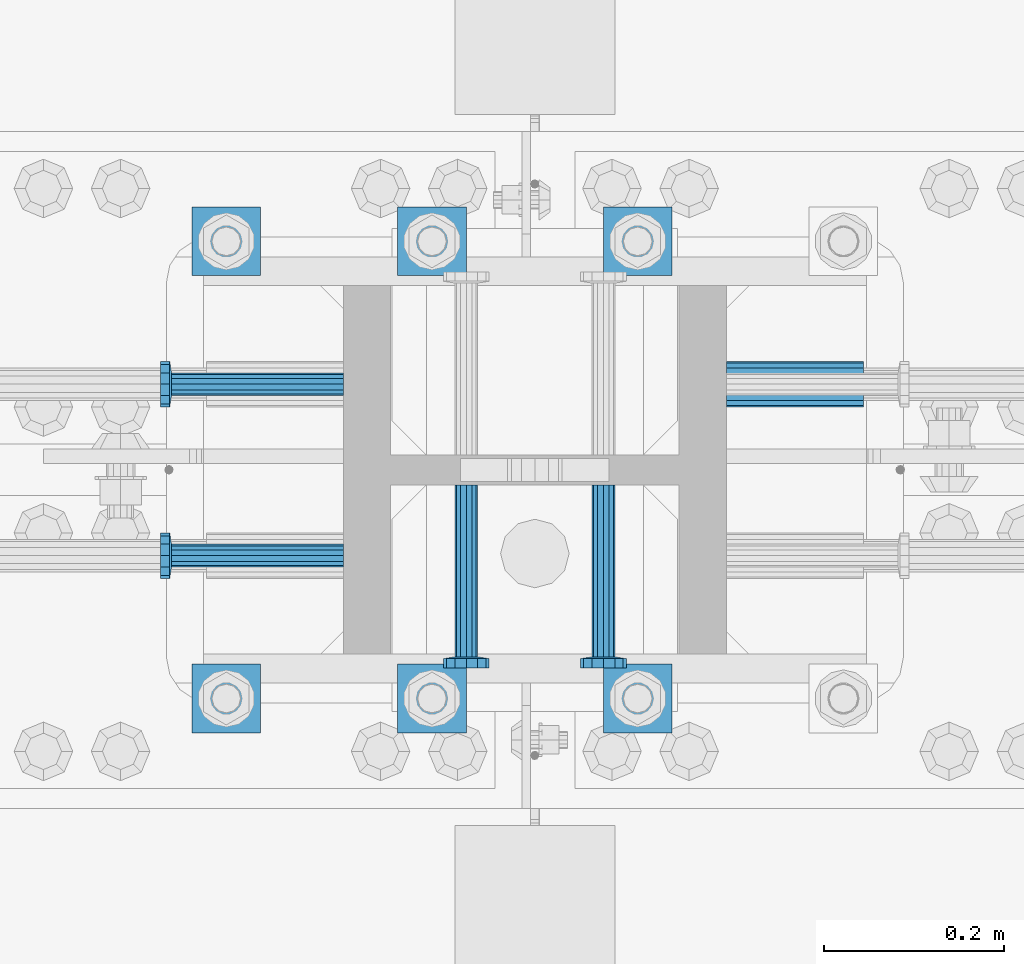
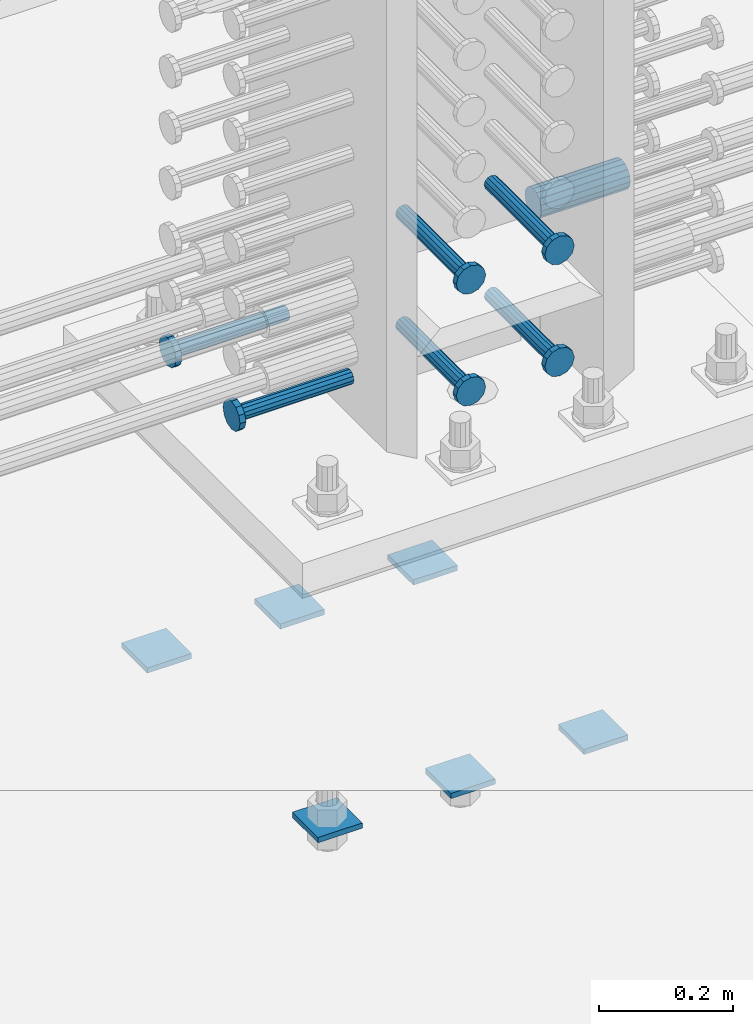
# One storey, part 1231 of 1763: 13 beams, 2 elements without a shape of their own.
"""IFC2X3 building model written with IfcOpenShell, lengths in millimetres."""

from ifc_helpers import new_model, si_unit, frame, origin_with_axes, place, context, subcontext, project, spatial, faceted_brep, material, type_object, element, aggregate, save


model = new_model("IFC2X3")

# Units and contexts
model_context = context("Model", 3, precision=1e-05, world=origin_with_axes())
body_context = subcontext(model_context, "Body", "Model", "MODEL_VIEW")
ifc_project = project(units=[si_unit("LENGTHUNIT", "METRE", prefix="MILLI"), si_unit("AREAUNIT", "SQUARE_METRE"), si_unit("VOLUMEUNIT", "CUBIC_METRE"), si_unit("MASSUNIT", "GRAM", prefix="KILO"), si_unit("TIMEUNIT", "SECOND"), si_unit("PLANEANGLEUNIT", "RADIAN"), si_unit("SOLIDANGLEUNIT", "STERADIAN"), si_unit("THERMODYNAMICTEMPERATUREUNIT", "DEGREE_CELSIUS"), si_unit("LUMINOUSINTENSITYUNIT", "LUMEN")], contexts=[model_context])

# Site, building, storey
site_placement = place(None, origin_with_axes())
site = spatial("IfcSite", under=ifc_project, at=site_placement, CompositionType="ELEMENT")
building_placement = place(site_placement, origin_with_axes())
building = spatial("IfcBuilding", under=site, at=building_placement, Name="Undefined", CompositionType="ELEMENT")
storey_placement = place(building_placement, origin_with_axes())
storey = spatial("IfcBuildingStorey", under=building, at=storey_placement, Name="Undefined", CompositionType="ELEMENT", Elevation=0.0)

# Assembly, beams
assembly_1_placement = place(storey_placement, origin_with_axes())
assembly_1 = element("IfcElementAssembly", 1, at=assembly_1_placement, inside=storey, Name="TEMPLATE", AssemblyPlace="NOTDEFINED", PredefinedType="RIGID_FRAME")
ifc_material_1 = material(Name="STEEL/A36")
beam_type_1 = type_object("IfcBeamType", PredefinedType="NOTDEFINED")
beam_1_placement = place(assembly_1_placement, frame((-49250.0372736986, 203.200000000003, 3348.0375), z_axis=(0.0, 1.0, 0.0), x_axis=(-1.0, 0.0, 0.0)))
beam_1 = element("IfcBeam", 2, at=beam_1_placement, type_object=beam_type_1, material=ifc_material_1, Name="WASHER PLATE", context=body_context, shape_type="Brep", body=[
    faceted_brep([(0.0, 4.76249999999709, -38.1000000000004), (0.0, 4.76249999999709, 38.1000000000004), (76.2000000000007, 4.76249999999982, 38.0999999999985), (76.2000000000007, 4.76249999999982, -38.0999999999985), (0.0, -4.76249999999709, 38.1000000000004), (76.2000000000007, -4.76249999999982, 38.0999999999985), (0.0, -4.76249999999709, -38.1000000000004), (76.2000000000007, -4.76249999999982, -38.0999999999985)], [[[0, 1, 2, 3]], [[1, 4, 5, 2]], [[4, 6, 7, 5]], [[6, 0, 3, 7]], [[5, 7, 3, 2]], [[6, 4, 1, 0]]]),
])
beam_2_placement = place(assembly_1_placement, frame((-49250.0372736986, 711.200000000003, 3348.0375), z_axis=(0.0, 1.0, 0.0), x_axis=(-1.0, 0.0, 0.0)))
beam_2 = element("IfcBeam", 3, at=beam_2_placement, type_object=beam_type_1, material=ifc_material_1, Name="WASHER PLATE", context=body_context, shape_type="Brep", body=[
    faceted_brep([(0.0, 4.76249999999709, -38.1000000000004), (0.0, 4.76249999999709, 38.1000000000004), (76.2000000000007, 4.76249999999982, 38.0999999999985), (76.2000000000007, 4.76249999999982, -38.0999999999985), (0.0, -4.76249999999709, 38.1000000000004), (76.2000000000007, -4.76249999999982, 38.0999999999985), (0.0, -4.76249999999709, -38.1000000000004), (76.2000000000007, -4.76249999999982, -38.0999999999985)], [[[0, 1, 2, 3]], [[1, 4, 5, 2]], [[4, 6, 7, 5]], [[6, 0, 3, 7]], [[5, 7, 3, 2]], [[6, 4, 1, 0]]]),
])
beam_3_placement = place(assembly_1_placement, frame((-49478.6372736986, 203.200000000003, 3348.0375), z_axis=(0.0, 1.0, 0.0), x_axis=(-1.0, 0.0, 0.0)))
beam_3 = element("IfcBeam", 4, at=beam_3_placement, type_object=beam_type_1, material=ifc_material_1, Name="WASHER PLATE", context=body_context, shape_type="Brep", body=[
    faceted_brep([(0.0, 4.76249999999709, -38.1000000000004), (0.0, 4.76249999999709, 38.1000000000004), (76.2000000000007, 4.76249999999982, 38.0999999999985), (76.2000000000007, 4.76249999999982, -38.0999999999985), (0.0, -4.76249999999709, 38.1000000000004), (76.2000000000007, -4.76249999999982, 38.0999999999985), (0.0, -4.76249999999709, -38.1000000000004), (76.2000000000007, -4.76249999999982, -38.0999999999985)], [[[0, 1, 2, 3]], [[1, 4, 5, 2]], [[4, 6, 7, 5]], [[6, 0, 3, 7]], [[5, 7, 3, 2]], [[6, 4, 1, 0]]]),
])
beam_4_placement = place(assembly_1_placement, frame((-49478.6372736986, 711.200000000003, 3348.0375), z_axis=(0.0, 1.0, 0.0), x_axis=(-1.0, 0.0, 0.0)))
beam_4 = element("IfcBeam", 5, at=beam_4_placement, type_object=beam_type_1, material=ifc_material_1, Name="WASHER PLATE", context=body_context, shape_type="Brep", body=[
    faceted_brep([(0.0, 4.76249999999709, -38.1000000000004), (0.0, 4.76249999999709, 38.1000000000004), (76.2000000000007, 4.76249999999982, 38.0999999999985), (76.2000000000007, 4.76249999999982, -38.0999999999985), (0.0, -4.76249999999709, 38.1000000000004), (76.2000000000007, -4.76249999999982, 38.0999999999985), (0.0, -4.76249999999709, -38.1000000000004), (76.2000000000007, -4.76249999999982, -38.0999999999985)], [[[0, 1, 2, 3]], [[1, 4, 5, 2]], [[4, 6, 7, 5]], [[6, 0, 3, 7]], [[5, 7, 3, 2]], [[6, 4, 1, 0]]]),
])
beam_5_placement = place(assembly_1_placement, frame((-49707.2372736986, 203.200000000003, 3348.0375), z_axis=(0.0, 1.0, 0.0), x_axis=(-1.0, 0.0, 0.0)))
beam_5 = element("IfcBeam", 6, at=beam_5_placement, type_object=beam_type_1, material=ifc_material_1, Name="WASHER PLATE", context=body_context, shape_type="Brep", body=[
    faceted_brep([(0.0, 4.76249999999709, -38.1000000000004), (0.0, 4.76249999999709, 38.1000000000004), (76.2000000000007, 4.76249999999982, 38.0999999999985), (76.2000000000007, 4.76249999999982, -38.0999999999985), (0.0, -4.76249999999709, 38.1000000000004), (76.2000000000007, -4.76249999999982, 38.0999999999985), (0.0, -4.76249999999709, -38.1000000000004), (76.2000000000007, -4.76249999999982, -38.0999999999985)], [[[0, 1, 2, 3]], [[1, 4, 5, 2]], [[4, 6, 7, 5]], [[6, 0, 3, 7]], [[5, 7, 3, 2]], [[6, 4, 1, 0]]]),
])
beam_6_placement = place(assembly_1_placement, frame((-49707.2372736986, 711.200000000003, 3348.0375), z_axis=(0.0, 1.0, 0.0), x_axis=(-1.0, 0.0, 0.0)))
beam_6 = element("IfcBeam", 7, at=beam_6_placement, type_object=beam_type_1, material=ifc_material_1, Name="WASHER PLATE", context=body_context, shape_type="Brep", body=[
    faceted_brep([(0.0, 4.76249999999709, -38.1000000000004), (0.0, 4.76249999999709, 38.1000000000004), (76.2000000000007, 4.76249999999982, 38.0999999999985), (76.2000000000007, 4.76249999999982, -38.0999999999985), (0.0, -4.76249999999709, 38.1000000000004), (76.2000000000007, -4.76249999999982, 38.0999999999985), (0.0, -4.76249999999709, -38.1000000000004), (76.2000000000007, -4.76249999999982, -38.0999999999985)], [[[0, 1, 2, 3]], [[1, 4, 5, 2]], [[4, 6, 7, 5]], [[6, 0, 3, 7]], [[5, 7, 3, 2]], [[6, 4, 1, 0]]]),
])
aggregate(assembly_1, [beam_1, beam_2, beam_3, beam_4, beam_5, beam_6])

assembly_2_placement = place(storey_placement, origin_with_axes())
assembly_2 = element("IfcElementAssembly", 8, at=assembly_2_placement, inside=storey, Name="COLUMN", AssemblyPlace="NOTDEFINED", PredefinedType="RIGID_FRAME")
ifc_material_2 = material(Name="STEEL/A706-GR.80")
beam_type_2 = type_object("IfcBeamType", PredefinedType="NOTDEFINED")
beam_7_placement = place(assembly_2_placement, frame((-49189.7122179961, 552.449999999415, 4064.0), z_axis=(0.0, 0.0, 1.0), x_axis=(1.0, 0.0, 0.0)))
beam_7 = element("IfcBeam", 9, at=beam_7_placement, type_object=beam_type_2, material=ifc_material_2, Name="HALF COUPLER F", context=body_context, shape_type="Brep", body=[
    faceted_brep([(32.7659999999996, -8.95349999999962, -15.507916905568), (32.7659999999996, 0.0, -17.9070000000002), (32.7659999999996, 8.95349999999962, -15.507916905568), (32.7659999999996, 15.507916905568, -8.95350000000008), (32.7659999999996, 17.9069999999992, 0.0), (32.7659999999996, 15.507916905568, 8.95350000000008), (32.7659999999996, 8.95349999999962, 15.507916905568), (32.7659999999996, 0.0, 17.9070000000002), (32.7659999999996, -8.95349999999962, 15.507916905568), (32.7659999999996, -15.507916905568, 8.95350000000008), (32.7659999999996, -17.9069999999992, 0.0), (32.7659999999996, -15.507916905568, -8.95350000000008), (152.400103102711, -15.507916905568, 8.95350000000008), (152.400103102711, -8.95349999999962, 15.507916905568), (152.400103102711, -17.9069999999992, 0.0), (152.400103102711, -15.507916905568, -8.95350000000008), (152.400103102711, -8.95349999999962, -15.507916905568), (152.400103102711, 0.0, -17.9070000000002), (152.400103102711, 8.95349999999962, -15.507916905568), (152.400103102711, 15.507916905568, -8.95350000000008), (152.400103102711, 17.9069999999992, 0.0), (152.400103102711, 15.507916905568, 8.95350000000008), (152.400103102711, 8.95349999999962, 15.507916905568), (152.400103102711, 0.0, 17.9070000000002), (0.0, -23.466540125788, 9.72015918207308), (0.0, -17.9605122421381, 17.9605122421385), (0.0, -9.72015918207398, 23.4665401257867), (0.0, 0.0, 25.4000000000001), (0.0, 9.72015918207398, 23.4665401257867), (0.0, 17.9605122421381, 17.9605122421385), (0.0, 23.466540125788, 9.72015918207308), (0.0, 25.4000000000015, 0.0), (0.0, 23.466540125788, -9.72015918207308), (0.0, 17.9605122421381, -17.9605122421385), (0.0, 9.72015918207398, -23.4665401257867), (0.0, 0.0, -25.4000000000001), (0.0, -9.72015918207398, -23.4665401257867), (0.0, -17.9605122421381, -17.9605122421385), (0.0, -23.466540125788, -9.72015918207308), (0.0, -25.4000000000015, 0.0), (152.400103102711, -25.4000000000015, 0.0), (152.400103102711, -23.466540125788, 9.72015918207308), (152.400103102711, -17.9605122421381, 17.9605122421385), (152.400103102711, -9.72015918207398, 23.4665401257867), (152.400103102711, 0.0, 25.4000000000001), (152.400103102711, 9.72015918207398, 23.4665401257867), (152.400103102711, 17.9605122421381, 17.9605122421385), (152.400103102711, 23.466540125788, 9.72015918207308), (152.400103102711, 25.4000000000015, 0.0), (152.400103102711, 23.466540125788, -9.72015918207308), (152.400103102711, 17.9605122421381, -17.9605122421385), (152.400103102711, 9.72015918207398, -23.4665401257867), (152.400103102711, 0.0, -25.4000000000001), (152.400103102711, -9.72015918207398, -23.4665401257867), (152.400103102711, -17.9605122421381, -17.9605122421385), (152.400103102711, -23.466540125788, -9.72015918207308)], [[[0, 1, 2, 3, 4, 5, 6, 7, 8, 9, 10, 11]], [[12, 9, 8, 13]], [[14, 10, 9, 12]], [[15, 11, 10, 14]], [[16, 0, 11, 15]], [[17, 1, 0, 16]], [[18, 2, 1, 17]], [[19, 3, 2, 18]], [[20, 4, 3, 19]], [[21, 5, 4, 20]], [[22, 6, 5, 21]], [[23, 7, 6, 22]], [[13, 8, 7, 23]], [[24, 25, 26, 27, 28, 29, 30, 31, 32, 33, 34, 35, 36, 37, 38, 39]], [[24, 39, 40, 41]], [[25, 24, 41, 42]], [[26, 25, 42, 43]], [[27, 26, 43, 44]], [[28, 27, 44, 45]], [[29, 28, 45, 46]], [[30, 29, 46, 47]], [[31, 30, 47, 48]], [[32, 31, 48, 49]], [[33, 32, 49, 50]], [[34, 33, 50, 51]], [[35, 34, 51, 52]], [[36, 35, 52, 53]], [[37, 36, 53, 54]], [[38, 37, 54, 55]], [[39, 38, 55, 40]], [[54, 53, 52, 51, 50, 49, 48, 47, 46, 45, 44, 43, 42, 41, 40, 55], [21, 20, 19, 18, 17, 16, 15, 14, 12, 13, 23, 22]]]),
])
ifc_material_3 = material(Name="STEEL/A108")
beam_type_3 = type_object("IfcBeamType", PredefinedType="NOTDEFINED")
beam_8_placement = place(assembly_2_placement, frame((-49615.1622049637, 361.949999999994, 4013.2), z_axis=(0.0, 1.0, 0.0), x_axis=(-1.0, 0.0, 0.0)))
beam_8 = element("IfcBeam", 10, at=beam_8_placement, type_object=beam_type_3, material=ifc_material_3, Name="HEADED STUD ANCHOR", context=body_context, shape_type="Brep", body=[
    faceted_brep([(0.0, -12.6999999999971, -1.81898940354586e-12), (3.63797880709171e-12, -11.0, -6.34999990463257), (191.00799999576, -11.0, -6.34999990454889), (191.007999995752, -12.6999998092651, 8.36735125631094e-11), (7.27595761418343e-12, -6.34999990463257, -11.0), (191.00799999576, -6.34999990463257, -10.9999999999163), (3.63797880709171e-12, 0.0, -12.6999998092651), (191.00799999576, 0.0, -12.6999998091815), (7.27595761418343e-12, 6.34999990463257, -11.0), (191.00799999576, 6.34999990463257, -10.9999999999163), (3.63797880709171e-12, 11.0, -6.34999990463257), (191.00799999576, 11.0, -6.34999990454889), (0.0, 12.6999999999971, -1.81898940354586e-12), (191.007999995752, 12.6999998092651, 8.36735125631094e-11), (0.0, 11.0, 6.34999990463257), (191.007999995752, 11.0, 6.34999990471624), (-3.63797880709171e-12, 6.34999990463257, 11.0), (191.007999995749, 6.34999990463257, 11.0000000000837), (-3.63797880709171e-12, 0.0, 12.6999998092651), (191.007999995749, 0.0, 12.6999998093488), (-3.63797880709171e-12, -6.34999990463257, 11.0), (191.007999995749, -6.34999990463257, 11.0000000000837), (0.0, -11.0, 6.34999990463257), (191.007999995752, -11.0, 6.34999990471624), (193.039999995715, -22.0, -12.6999998091796), (193.039999995708, -25.3999996185303, 8.54925019666553e-11), (193.039999995719, -12.6999998092651, -21.9999999999145), (193.039999995719, 0.0, -25.3999996184448), (193.039999995719, 12.6999998092651, -21.9999999999145), (193.039999995715, 22.0, -12.6999998091796), (193.039999995708, 25.3999996185303, 8.54925019666553e-11), (193.039999995704, 22.0, 12.6999998093506), (193.039999995701, 12.6999998092651, 22.0000000000855), (193.039999995697, 0.0, 25.3999996186158), (193.039999995701, -12.6999998092651, 22.0000000000855), (193.039999995704, -22.0, 12.6999998093506), (203.199999995486, -22.0, -12.6999998091742), (203.199999995482, -25.3999996185303, 9.09494701772928e-11), (203.199999995493, -12.6999998092651, -21.9999999999091), (203.199999995493, 0.0, -25.3999996184393), (203.199999995493, 12.6999998092651, -21.9999999999091), (203.199999995486, 22.0, -12.6999998091742), (203.199999995482, 25.3999996185303, 9.09494701772928e-11), (203.199999995479, 22.0, 12.6999998093561), (203.199999995475, 12.6999998092651, 22.0000000000909), (203.199999995471, 0.0, 25.3999996186212), (203.199999995475, -12.6999998092651, 22.0000000000909), (203.199999995479, -22.0, 12.6999998093561)], [[[0, 1, 2, 3]], [[1, 4, 5, 2]], [[4, 6, 7, 5]], [[6, 8, 9, 7]], [[8, 10, 11, 9]], [[10, 12, 13, 11]], [[12, 14, 15, 13]], [[14, 16, 17, 15]], [[16, 18, 19, 17]], [[18, 20, 21, 19]], [[20, 22, 23, 21]], [[22, 0, 3, 23]], [[22, 20, 18, 16, 14, 12, 10, 8, 6, 4, 1, 0]], [[3, 2, 24, 25]], [[2, 5, 26, 24]], [[5, 7, 27, 26]], [[7, 9, 28, 27]], [[9, 11, 29, 28]], [[11, 13, 30, 29]], [[13, 15, 31, 30]], [[15, 17, 32, 31]], [[17, 19, 33, 32]], [[19, 21, 34, 33]], [[21, 23, 35, 34]], [[23, 3, 25, 35]], [[25, 24, 36, 37]], [[24, 26, 38, 36]], [[26, 27, 39, 38]], [[27, 28, 40, 39]], [[28, 29, 41, 40]], [[29, 30, 42, 41]], [[30, 31, 43, 42]], [[31, 32, 44, 43]], [[32, 33, 45, 44]], [[33, 34, 46, 45]], [[34, 35, 47, 46]], [[35, 25, 37, 47]], [[38, 39, 40, 41, 42, 43, 44, 45, 46, 47, 37, 36]]]),
])
beam_9_placement = place(assembly_2_placement, frame((-49615.1621362282, 552.44999999982, 4013.2), z_axis=(0.0, 1.0, 0.0), x_axis=(-1.0, 0.0, 0.0)))
beam_9 = element("IfcBeam", 11, at=beam_9_placement, type_object=beam_type_3, material=ifc_material_3, Name="HEADED STUD ANCHOR", context=body_context, shape_type="Brep", body=[
    faceted_brep([(0.0, -12.6999999999971, -1.81898940354586e-12), (3.63797880709171e-12, -11.0, -6.34999990463257), (191.00799999576, -11.0, -6.34999990454889), (191.007999995752, -12.6999998092651, 8.36735125631094e-11), (7.27595761418343e-12, -6.34999990463257, -11.0), (191.00799999576, -6.34999990463257, -10.9999999999163), (3.63797880709171e-12, 0.0, -12.6999998092651), (191.00799999576, 0.0, -12.6999998091815), (7.27595761418343e-12, 6.34999990463257, -11.0), (191.00799999576, 6.34999990463257, -10.9999999999163), (3.63797880709171e-12, 11.0, -6.34999990463257), (191.00799999576, 11.0, -6.34999990454889), (0.0, 12.6999999999971, -1.81898940354586e-12), (191.007999995752, 12.6999998092651, 8.36735125631094e-11), (0.0, 11.0, 6.34999990463257), (191.007999995752, 11.0, 6.34999990471624), (-3.63797880709171e-12, 6.34999990463257, 11.0), (191.007999995749, 6.34999990463257, 11.0000000000837), (-3.63797880709171e-12, 0.0, 12.6999998092651), (191.007999995749, 0.0, 12.6999998093488), (-3.63797880709171e-12, -6.34999990463257, 11.0), (191.007999995749, -6.34999990463257, 11.0000000000837), (0.0, -11.0, 6.34999990463257), (191.007999995752, -11.0, 6.34999990471624), (193.039999995715, -22.0, -12.6999998091796), (193.039999995708, -25.3999996185303, 8.54925019666553e-11), (193.039999995719, -12.6999998092651, -21.9999999999145), (193.039999995719, 0.0, -25.3999996184448), (193.039999995719, 12.6999998092651, -21.9999999999145), (193.039999995715, 22.0, -12.6999998091796), (193.039999995708, 25.3999996185303, 8.54925019666553e-11), (193.039999995704, 22.0, 12.6999998093506), (193.039999995701, 12.6999998092651, 22.0000000000855), (193.039999995697, 0.0, 25.3999996186158), (193.039999995701, -12.6999998092651, 22.0000000000855), (193.039999995704, -22.0, 12.6999998093506), (203.199999995486, -22.0, -12.6999998091742), (203.199999995482, -25.3999996185303, 9.09494701772928e-11), (203.199999995493, -12.6999998092651, -21.9999999999091), (203.199999995493, 0.0, -25.3999996184393), (203.199999995493, 12.6999998092651, -21.9999999999091), (203.199999995486, 22.0, -12.6999998091742), (203.199999995482, 25.3999996185303, 9.09494701772928e-11), (203.199999995479, 22.0, 12.6999998093561), (203.199999995475, 12.6999998092651, 22.0000000000909), (203.199999995471, 0.0, 25.3999996186212), (203.199999995475, -12.6999998092651, 22.0000000000909), (203.199999995479, -22.0, 12.6999998093561)], [[[0, 1, 2, 3]], [[1, 4, 5, 2]], [[4, 6, 7, 5]], [[6, 8, 9, 7]], [[8, 10, 11, 9]], [[10, 12, 13, 11]], [[12, 14, 15, 13]], [[14, 16, 17, 15]], [[16, 18, 19, 17]], [[18, 20, 21, 19]], [[20, 22, 23, 21]], [[22, 0, 3, 23]], [[22, 20, 18, 16, 14, 12, 10, 8, 6, 4, 1, 0]], [[3, 2, 24, 25]], [[2, 5, 26, 24]], [[5, 7, 27, 26]], [[7, 9, 28, 27]], [[9, 11, 29, 28]], [[11, 13, 30, 29]], [[13, 15, 31, 30]], [[15, 17, 32, 31]], [[17, 19, 33, 32]], [[19, 21, 34, 33]], [[21, 23, 35, 34]], [[23, 3, 25, 35]], [[25, 24, 36, 37]], [[24, 26, 38, 36]], [[26, 27, 39, 38]], [[27, 28, 40, 39]], [[28, 29, 41, 40]], [[29, 30, 42, 41]], [[30, 31, 43, 42]], [[31, 32, 44, 43]], [[32, 33, 45, 44]], [[33, 34, 46, 45]], [[34, 35, 47, 46]], [[35, 25, 37, 47]], [[38, 39, 40, 41, 42, 43, 44, 45, 46, 47, 37, 36]]]),
])
beam_10_placement = place(assembly_2_placement, frame((-49478.6373420916, 440.530999885726, 4216.40000000002), z_axis=(1.0, 0.0, 0.0), x_axis=(0.0, -1.0, 0.0)))
beam_10 = element("IfcBeam", 12, at=beam_10_placement, type_object=beam_type_3, material=ifc_material_3, Name="HEADED STUD ANCHOR", context=body_context, shape_type="Brep", body=[
    faceted_brep([(0.0, -12.6999999999971, -1.81898940354586e-12), (3.63797880709171e-12, -11.0, -6.34999990463257), (191.00799999576, -11.0, -6.34999990454889), (191.007999995752, -12.6999998092651, 8.36735125631094e-11), (7.27595761418343e-12, -6.34999990463257, -11.0), (191.00799999576, -6.34999990463257, -10.9999999999163), (3.63797880709171e-12, 0.0, -12.6999998092651), (191.00799999576, 0.0, -12.6999998091815), (7.27595761418343e-12, 6.34999990463257, -11.0), (191.00799999576, 6.34999990463257, -10.9999999999163), (3.63797880709171e-12, 11.0, -6.34999990463257), (191.00799999576, 11.0, -6.34999990454889), (0.0, 12.6999999999971, -1.81898940354586e-12), (191.007999995752, 12.6999998092651, 8.36735125631094e-11), (0.0, 11.0, 6.34999990463257), (191.007999995752, 11.0, 6.34999990471624), (-3.63797880709171e-12, 6.34999990463257, 11.0), (191.007999995749, 6.34999990463257, 11.0000000000837), (-3.63797880709171e-12, 0.0, 12.6999998092651), (191.007999995749, 0.0, 12.6999998093488), (-3.63797880709171e-12, -6.34999990463257, 11.0), (191.007999995749, -6.34999990463257, 11.0000000000837), (0.0, -11.0, 6.34999990463257), (191.007999995752, -11.0, 6.34999990471624), (193.039999995715, -22.0, -12.6999998091796), (193.039999995708, -25.3999996185303, 8.54925019666553e-11), (193.039999995719, -12.6999998092651, -21.9999999999145), (193.039999995719, 0.0, -25.3999996184448), (193.039999995719, 12.6999998092651, -21.9999999999145), (193.039999995715, 22.0, -12.6999998091796), (193.039999995708, 25.3999996185303, 8.54925019666553e-11), (193.039999995704, 22.0, 12.6999998093506), (193.039999995701, 12.6999998092651, 22.0000000000855), (193.039999995697, 0.0, 25.3999996186158), (193.039999995701, -12.6999998092651, 22.0000000000855), (193.039999995704, -22.0, 12.6999998093506), (203.199999995486, -22.0, -12.6999998091742), (203.199999995482, -25.3999996185303, 9.09494701772928e-11), (203.199999995493, -12.6999998092651, -21.9999999999091), (203.199999995493, 0.0, -25.3999996184393), (203.199999995493, 12.6999998092651, -21.9999999999091), (203.199999995486, 22.0, -12.6999998091742), (203.199999995482, 25.3999996185303, 9.09494701772928e-11), (203.199999995479, 22.0, 12.6999998093561), (203.199999995475, 12.6999998092651, 22.0000000000909), (203.199999995471, 0.0, 25.3999996186212), (203.199999995475, -12.6999998092651, 22.0000000000909), (203.199999995479, -22.0, 12.6999998093561)], [[[0, 1, 2, 3]], [[1, 4, 5, 2]], [[4, 6, 7, 5]], [[6, 8, 9, 7]], [[8, 10, 11, 9]], [[10, 12, 13, 11]], [[12, 14, 15, 13]], [[14, 16, 17, 15]], [[16, 18, 19, 17]], [[18, 20, 21, 19]], [[20, 22, 23, 21]], [[22, 0, 3, 23]], [[22, 20, 18, 16, 14, 12, 10, 8, 6, 4, 1, 0]], [[3, 2, 24, 25]], [[2, 5, 26, 24]], [[5, 7, 27, 26]], [[7, 9, 28, 27]], [[9, 11, 29, 28]], [[11, 13, 30, 29]], [[13, 15, 31, 30]], [[15, 17, 32, 31]], [[17, 19, 33, 32]], [[19, 21, 34, 33]], [[21, 23, 35, 34]], [[23, 3, 25, 35]], [[25, 24, 36, 37]], [[24, 26, 38, 36]], [[26, 27, 39, 38]], [[27, 28, 40, 39]], [[28, 29, 41, 40]], [[29, 30, 42, 41]], [[30, 31, 43, 42]], [[31, 32, 44, 43]], [[32, 33, 45, 44]], [[33, 34, 46, 45]], [[34, 35, 47, 46]], [[35, 25, 37, 47]], [[38, 39, 40, 41, 42, 43, 44, 45, 46, 47, 37, 36]]]),
])
beam_11_placement = place(assembly_2_placement, frame((-49326.2373420926, 440.531000000003, 4216.40000000002), z_axis=(1.0, 0.0, 0.0), x_axis=(0.0, -1.0, 0.0)))
beam_11 = element("IfcBeam", 13, at=beam_11_placement, type_object=beam_type_3, material=ifc_material_3, Name="HEADED STUD ANCHOR", context=body_context, shape_type="Brep", body=[
    faceted_brep([(0.0, -12.6999999999971, -1.81898940354586e-12), (3.63797880709171e-12, -11.0, -6.34999990463257), (191.00799999576, -11.0, -6.34999990454889), (191.007999995752, -12.6999998092651, 8.36735125631094e-11), (7.27595761418343e-12, -6.34999990463257, -11.0), (191.00799999576, -6.34999990463257, -10.9999999999163), (3.63797880709171e-12, 0.0, -12.6999998092651), (191.00799999576, 0.0, -12.6999998091815), (7.27595761418343e-12, 6.34999990463257, -11.0), (191.00799999576, 6.34999990463257, -10.9999999999163), (3.63797880709171e-12, 11.0, -6.34999990463257), (191.00799999576, 11.0, -6.34999990454889), (0.0, 12.6999999999971, -1.81898940354586e-12), (191.007999995752, 12.6999998092651, 8.36735125631094e-11), (0.0, 11.0, 6.34999990463257), (191.007999995752, 11.0, 6.34999990471624), (-3.63797880709171e-12, 6.34999990463257, 11.0), (191.007999995749, 6.34999990463257, 11.0000000000837), (-3.63797880709171e-12, 0.0, 12.6999998092651), (191.007999995749, 0.0, 12.6999998093488), (-3.63797880709171e-12, -6.34999990463257, 11.0), (191.007999995749, -6.34999990463257, 11.0000000000837), (0.0, -11.0, 6.34999990463257), (191.007999995752, -11.0, 6.34999990471624), (193.039999995715, -22.0, -12.6999998091796), (193.039999995708, -25.3999996185303, 8.54925019666553e-11), (193.039999995719, -12.6999998092651, -21.9999999999145), (193.039999995719, 0.0, -25.3999996184448), (193.039999995719, 12.6999998092651, -21.9999999999145), (193.039999995715, 22.0, -12.6999998091796), (193.039999995708, 25.3999996185303, 8.54925019666553e-11), (193.039999995704, 22.0, 12.6999998093506), (193.039999995701, 12.6999998092651, 22.0000000000855), (193.039999995697, 0.0, 25.3999996186158), (193.039999995701, -12.6999998092651, 22.0000000000855), (193.039999995704, -22.0, 12.6999998093506), (203.199999995486, -22.0, -12.6999998091742), (203.199999995482, -25.3999996185303, 9.09494701772928e-11), (203.199999995493, -12.6999998092651, -21.9999999999091), (203.199999995493, 0.0, -25.3999996184393), (203.199999995493, 12.6999998092651, -21.9999999999091), (203.199999995486, 22.0, -12.6999998091742), (203.199999995482, 25.3999996185303, 9.09494701772928e-11), (203.199999995479, 22.0, 12.6999998093561), (203.199999995475, 12.6999998092651, 22.0000000000909), (203.199999995471, 0.0, 25.3999996186212), (203.199999995475, -12.6999998092651, 22.0000000000909), (203.199999995479, -22.0, 12.6999998093561)], [[[0, 1, 2, 3]], [[1, 4, 5, 2]], [[4, 6, 7, 5]], [[6, 8, 9, 7]], [[8, 10, 11, 9]], [[10, 12, 13, 11]], [[12, 14, 15, 13]], [[14, 16, 17, 15]], [[16, 18, 19, 17]], [[18, 20, 21, 19]], [[20, 22, 23, 21]], [[22, 0, 3, 23]], [[22, 20, 18, 16, 14, 12, 10, 8, 6, 4, 1, 0]], [[3, 2, 24, 25]], [[2, 5, 26, 24]], [[5, 7, 27, 26]], [[7, 9, 28, 27]], [[9, 11, 29, 28]], [[11, 13, 30, 29]], [[13, 15, 31, 30]], [[15, 17, 32, 31]], [[17, 19, 33, 32]], [[19, 21, 34, 33]], [[21, 23, 35, 34]], [[23, 3, 25, 35]], [[25, 24, 36, 37]], [[24, 26, 38, 36]], [[26, 27, 39, 38]], [[27, 28, 40, 39]], [[28, 29, 41, 40]], [[29, 30, 42, 41]], [[30, 31, 43, 42]], [[31, 32, 44, 43]], [[32, 33, 45, 44]], [[33, 34, 46, 45]], [[34, 35, 47, 46]], [[35, 25, 37, 47]], [[38, 39, 40, 41, 42, 43, 44, 45, 46, 47, 37, 36]]]),
])
beam_12_placement = place(assembly_2_placement, frame((-49478.6372733567, 440.530999885726, 4013.2), z_axis=(1.0, 0.0, 0.0), x_axis=(0.0, -1.0, 0.0)))
beam_12 = element("IfcBeam", 14, at=beam_12_placement, type_object=beam_type_3, material=ifc_material_3, Name="HEADED STUD ANCHOR", context=body_context, shape_type="Brep", body=[
    faceted_brep([(0.0, -12.6999999999971, -1.81898940354586e-12), (3.63797880709171e-12, -11.0, -6.34999990463257), (191.00799999576, -11.0, -6.34999990454889), (191.007999995752, -12.6999998092651, 8.36735125631094e-11), (7.27595761418343e-12, -6.34999990463257, -11.0), (191.00799999576, -6.34999990463257, -10.9999999999163), (3.63797880709171e-12, 0.0, -12.6999998092651), (191.00799999576, 0.0, -12.6999998091815), (7.27595761418343e-12, 6.34999990463257, -11.0), (191.00799999576, 6.34999990463257, -10.9999999999163), (3.63797880709171e-12, 11.0, -6.34999990463257), (191.00799999576, 11.0, -6.34999990454889), (0.0, 12.6999999999971, -1.81898940354586e-12), (191.007999995752, 12.6999998092651, 8.36735125631094e-11), (0.0, 11.0, 6.34999990463257), (191.007999995752, 11.0, 6.34999990471624), (-3.63797880709171e-12, 6.34999990463257, 11.0), (191.007999995749, 6.34999990463257, 11.0000000000837), (-3.63797880709171e-12, 0.0, 12.6999998092651), (191.007999995749, 0.0, 12.6999998093488), (-3.63797880709171e-12, -6.34999990463257, 11.0), (191.007999995749, -6.34999990463257, 11.0000000000837), (0.0, -11.0, 6.34999990463257), (191.007999995752, -11.0, 6.34999990471624), (193.039999995715, -22.0, -12.6999998091796), (193.039999995708, -25.3999996185303, 8.54925019666553e-11), (193.039999995719, -12.6999998092651, -21.9999999999145), (193.039999995719, 0.0, -25.3999996184448), (193.039999995719, 12.6999998092651, -21.9999999999145), (193.039999995715, 22.0, -12.6999998091796), (193.039999995708, 25.3999996185303, 8.54925019666553e-11), (193.039999995704, 22.0, 12.6999998093506), (193.039999995701, 12.6999998092651, 22.0000000000855), (193.039999995697, 0.0, 25.3999996186158), (193.039999995701, -12.6999998092651, 22.0000000000855), (193.039999995704, -22.0, 12.6999998093506), (203.199999995486, -22.0, -12.6999998091742), (203.199999995482, -25.3999996185303, 9.09494701772928e-11), (203.199999995493, -12.6999998092651, -21.9999999999091), (203.199999995493, 0.0, -25.3999996184393), (203.199999995493, 12.6999998092651, -21.9999999999091), (203.199999995486, 22.0, -12.6999998091742), (203.199999995482, 25.3999996185303, 9.09494701772928e-11), (203.199999995479, 22.0, 12.6999998093561), (203.199999995475, 12.6999998092651, 22.0000000000909), (203.199999995471, 0.0, 25.3999996186212), (203.199999995475, -12.6999998092651, 22.0000000000909), (203.199999995479, -22.0, 12.6999998093561)], [[[0, 1, 2, 3]], [[1, 4, 5, 2]], [[4, 6, 7, 5]], [[6, 8, 9, 7]], [[8, 10, 11, 9]], [[10, 12, 13, 11]], [[12, 14, 15, 13]], [[14, 16, 17, 15]], [[16, 18, 19, 17]], [[18, 20, 21, 19]], [[20, 22, 23, 21]], [[22, 0, 3, 23]], [[22, 20, 18, 16, 14, 12, 10, 8, 6, 4, 1, 0]], [[3, 2, 24, 25]], [[2, 5, 26, 24]], [[5, 7, 27, 26]], [[7, 9, 28, 27]], [[9, 11, 29, 28]], [[11, 13, 30, 29]], [[13, 15, 31, 30]], [[15, 17, 32, 31]], [[17, 19, 33, 32]], [[19, 21, 34, 33]], [[21, 23, 35, 34]], [[23, 3, 25, 35]], [[25, 24, 36, 37]], [[24, 26, 38, 36]], [[26, 27, 39, 38]], [[27, 28, 40, 39]], [[28, 29, 41, 40]], [[29, 30, 42, 41]], [[30, 31, 43, 42]], [[31, 32, 44, 43]], [[32, 33, 45, 44]], [[33, 34, 46, 45]], [[34, 35, 47, 46]], [[35, 25, 37, 47]], [[38, 39, 40, 41, 42, 43, 44, 45, 46, 47, 37, 36]]]),
])
beam_13_placement = place(assembly_2_placement, frame((-49326.2372733576, 440.531000000003, 4013.2), z_axis=(1.0, 0.0, 0.0), x_axis=(0.0, -1.0, 0.0)))
beam_13 = element("IfcBeam", 15, at=beam_13_placement, type_object=beam_type_3, material=ifc_material_3, Name="HEADED STUD ANCHOR", context=body_context, shape_type="Brep", body=[
    faceted_brep([(0.0, -12.6999999999971, -1.81898940354586e-12), (3.63797880709171e-12, -11.0, -6.34999990463257), (191.00799999576, -11.0, -6.34999990454889), (191.007999995752, -12.6999998092651, 8.36735125631094e-11), (7.27595761418343e-12, -6.34999990463257, -11.0), (191.00799999576, -6.34999990463257, -10.9999999999163), (3.63797880709171e-12, 0.0, -12.6999998092651), (191.00799999576, 0.0, -12.6999998091815), (7.27595761418343e-12, 6.34999990463257, -11.0), (191.00799999576, 6.34999990463257, -10.9999999999163), (3.63797880709171e-12, 11.0, -6.34999990463257), (191.00799999576, 11.0, -6.34999990454889), (0.0, 12.6999999999971, -1.81898940354586e-12), (191.007999995752, 12.6999998092651, 8.36735125631094e-11), (0.0, 11.0, 6.34999990463257), (191.007999995752, 11.0, 6.34999990471624), (-3.63797880709171e-12, 6.34999990463257, 11.0), (191.007999995749, 6.34999990463257, 11.0000000000837), (-3.63797880709171e-12, 0.0, 12.6999998092651), (191.007999995749, 0.0, 12.6999998093488), (-3.63797880709171e-12, -6.34999990463257, 11.0), (191.007999995749, -6.34999990463257, 11.0000000000837), (0.0, -11.0, 6.34999990463257), (191.007999995752, -11.0, 6.34999990471624), (193.039999995715, -22.0, -12.6999998091796), (193.039999995708, -25.3999996185303, 8.54925019666553e-11), (193.039999995719, -12.6999998092651, -21.9999999999145), (193.039999995719, 0.0, -25.3999996184448), (193.039999995719, 12.6999998092651, -21.9999999999145), (193.039999995715, 22.0, -12.6999998091796), (193.039999995708, 25.3999996185303, 8.54925019666553e-11), (193.039999995704, 22.0, 12.6999998093506), (193.039999995701, 12.6999998092651, 22.0000000000855), (193.039999995697, 0.0, 25.3999996186158), (193.039999995701, -12.6999998092651, 22.0000000000855), (193.039999995704, -22.0, 12.6999998093506), (203.199999995486, -22.0, -12.6999998091742), (203.199999995482, -25.3999996185303, 9.09494701772928e-11), (203.199999995493, -12.6999998092651, -21.9999999999091), (203.199999995493, 0.0, -25.3999996184393), (203.199999995493, 12.6999998092651, -21.9999999999091), (203.199999995486, 22.0, -12.6999998091742), (203.199999995482, 25.3999996185303, 9.09494701772928e-11), (203.199999995479, 22.0, 12.6999998093561), (203.199999995475, 12.6999998092651, 22.0000000000909), (203.199999995471, 0.0, 25.3999996186212), (203.199999995475, -12.6999998092651, 22.0000000000909), (203.199999995479, -22.0, 12.6999998093561)], [[[0, 1, 2, 3]], [[1, 4, 5, 2]], [[4, 6, 7, 5]], [[6, 8, 9, 7]], [[8, 10, 11, 9]], [[10, 12, 13, 11]], [[12, 14, 15, 13]], [[14, 16, 17, 15]], [[16, 18, 19, 17]], [[18, 20, 21, 19]], [[20, 22, 23, 21]], [[22, 0, 3, 23]], [[22, 20, 18, 16, 14, 12, 10, 8, 6, 4, 1, 0]], [[3, 2, 24, 25]], [[2, 5, 26, 24]], [[5, 7, 27, 26]], [[7, 9, 28, 27]], [[9, 11, 29, 28]], [[11, 13, 30, 29]], [[13, 15, 31, 30]], [[15, 17, 32, 31]], [[17, 19, 33, 32]], [[19, 21, 34, 33]], [[21, 23, 35, 34]], [[23, 3, 25, 35]], [[25, 24, 36, 37]], [[24, 26, 38, 36]], [[26, 27, 39, 38]], [[27, 28, 40, 39]], [[28, 29, 41, 40]], [[29, 30, 42, 41]], [[30, 31, 43, 42]], [[31, 32, 44, 43]], [[32, 33, 45, 44]], [[33, 34, 46, 45]], [[34, 35, 47, 46]], [[35, 25, 37, 47]], [[38, 39, 40, 41, 42, 43, 44, 45, 46, 47, 37, 36]]]),
])
aggregate(assembly_2, [beam_7, beam_8, beam_9, beam_10, beam_11, beam_12, beam_13])

save(model, "model.ifc")
